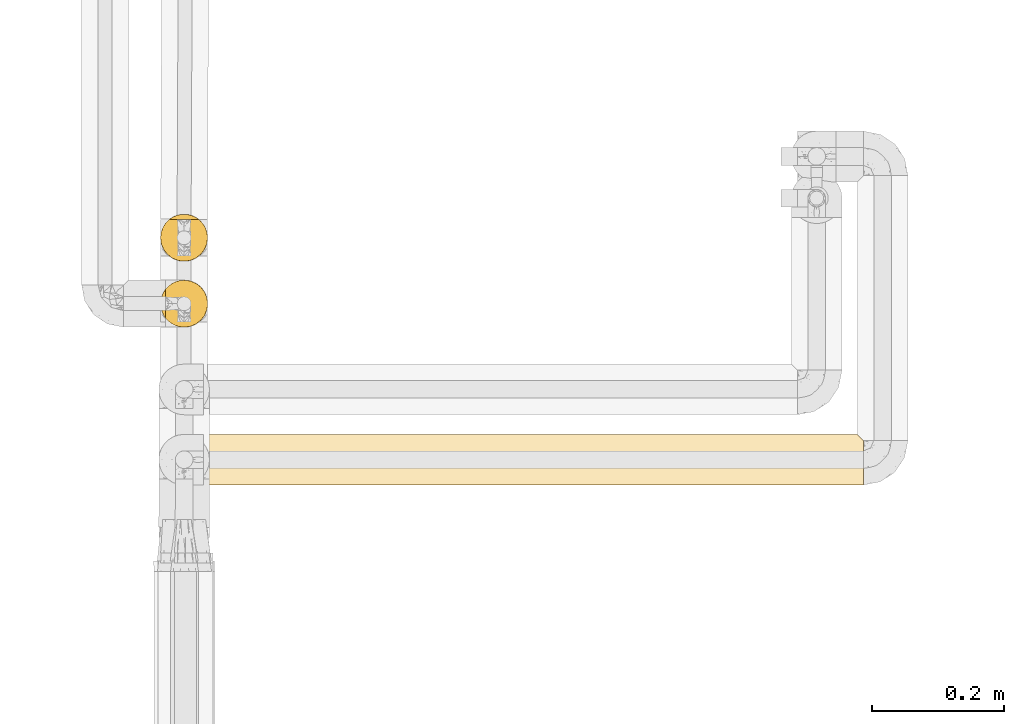
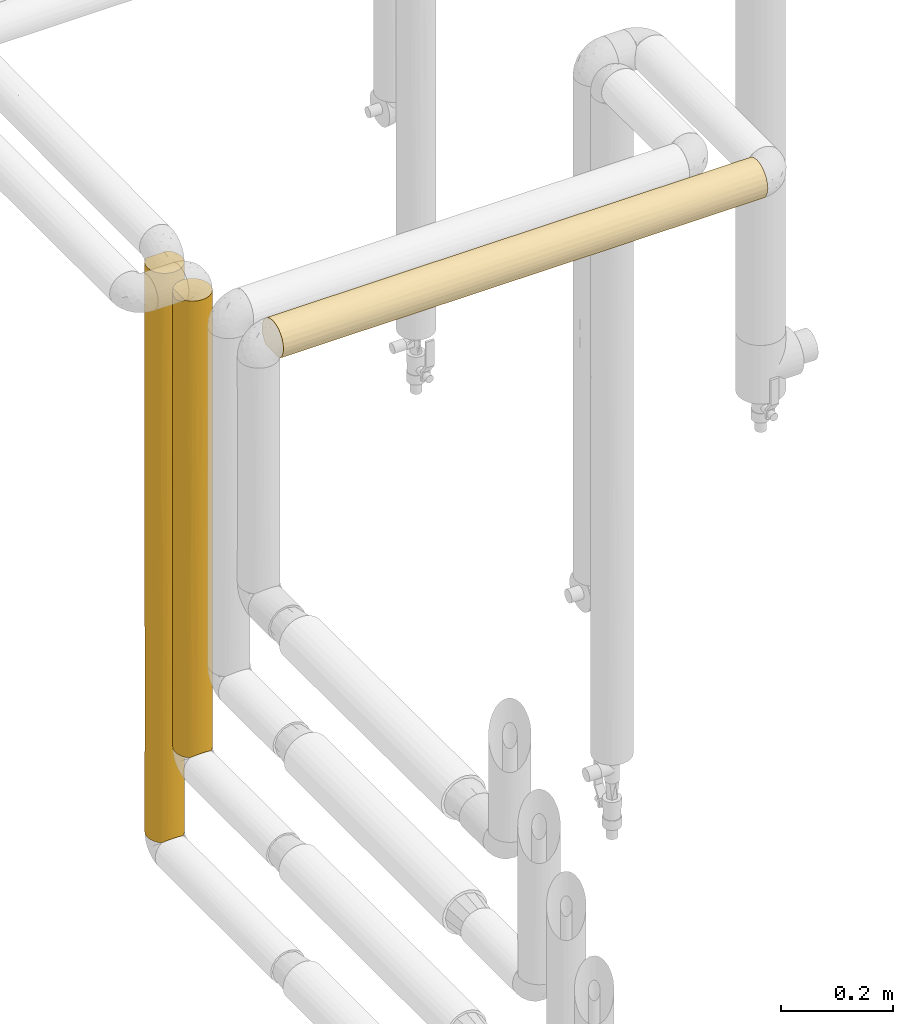
# One storey, part 29 of 827: 3 coverings.
"""IFC2X3 building model written with IfcOpenShell, lengths in millimetres."""

from ifc_helpers import new_model, entity, si_unit, converted_unit, derived_unit, direction, frame, origin, place, context, subcontext, project, spatial, faceted_brep, element, save


model = new_model("IFC2X3")

# Units and contexts
model_context = context("Model", 3, precision=0.01, world=origin(), true_north=direction((6.12303176911189e-17, 1.0)))
body_context = subcontext(model_context, "Body", "Model", "MODEL_VIEW")
ifc_project = project(units=[si_unit("LENGTHUNIT", "METRE", prefix="MILLI"), si_unit("AREAUNIT", "SQUARE_METRE"), si_unit("VOLUMEUNIT", "CUBIC_METRE"), converted_unit("PLANEANGLEUNIT", "DEGREE", entity("IfcRatioMeasure", 0.0174532925199433), si_unit("PLANEANGLEUNIT", "RADIAN"), dimensions=[0, 0, 0, 0, 0, 0, 0]), si_unit("MASSUNIT", "GRAM", prefix="KILO"), derived_unit("MASSDENSITYUNIT", [(si_unit("MASSUNIT", "GRAM", prefix="KILO"), 1), (si_unit("LENGTHUNIT", "METRE"), -3)]), derived_unit("MOMENTOFINERTIAUNIT", [(si_unit("LENGTHUNIT", "METRE"), 4)]), si_unit("TIMEUNIT", "SECOND"), si_unit("FREQUENCYUNIT", "HERTZ"), si_unit("THERMODYNAMICTEMPERATUREUNIT", "DEGREE_CELSIUS"), derived_unit("THERMALTRANSMITTANCEUNIT", [(si_unit("MASSUNIT", "GRAM", prefix="KILO"), 1), (si_unit("THERMODYNAMICTEMPERATUREUNIT", "KELVIN"), -1), (si_unit("TIMEUNIT", "SECOND"), -3)]), derived_unit("VOLUMETRICFLOWRATEUNIT", [(si_unit("LENGTHUNIT", "METRE"), 3), (si_unit("TIMEUNIT", "SECOND"), -1)]), derived_unit("MASSFLOWRATEUNIT", [(si_unit("MASSUNIT", "GRAM", prefix="KILO"), 1), (si_unit("TIMEUNIT", "SECOND"), -1)]), derived_unit("ROTATIONALFREQUENCYUNIT", [(si_unit("TIMEUNIT", "SECOND"), -1)]), si_unit("ELECTRICCURRENTUNIT", "AMPERE"), si_unit("ELECTRICVOLTAGEUNIT", "VOLT"), si_unit("POWERUNIT", "WATT"), si_unit("FORCEUNIT", "NEWTON", prefix="KILO"), si_unit("ILLUMINANCEUNIT", "LUX"), si_unit("LUMINOUSFLUXUNIT", "LUMEN"), si_unit("LUMINOUSINTENSITYUNIT", "CANDELA"), derived_unit("USERDEFINED", [(si_unit("MASSUNIT", "GRAM", prefix="KILO"), -1), (si_unit("LENGTHUNIT", "METRE"), -2), (si_unit("TIMEUNIT", "SECOND"), 3), (si_unit("LUMINOUSFLUXUNIT", "LUMEN"), 1)]), derived_unit("LINEARVELOCITYUNIT", [(si_unit("LENGTHUNIT", "METRE"), 1), (si_unit("TIMEUNIT", "SECOND"), -1)]), si_unit("PRESSUREUNIT", "PASCAL"), derived_unit("USERDEFINED", [(si_unit("LENGTHUNIT", "METRE"), -2), (si_unit("MASSUNIT", "GRAM", prefix="KILO"), 1), (si_unit("TIMEUNIT", "SECOND"), -2)]), derived_unit("LINEARFORCEUNIT", [(si_unit("MASSUNIT", "GRAM", prefix="KILO"), 1), (si_unit("LENGTHUNIT", "METRE"), 1), (si_unit("TIMEUNIT", "SECOND"), -2), (si_unit("LENGTHUNIT", "METRE"), -1)]), derived_unit("PLANARFORCEUNIT", [(si_unit("MASSUNIT", "GRAM", prefix="KILO"), 1), (si_unit("LENGTHUNIT", "METRE"), 1), (si_unit("TIMEUNIT", "SECOND"), -2), (si_unit("LENGTHUNIT", "METRE"), -2)])], contexts=[model_context])

# Site, building, storey
site_placement = place(None, origin())
site = spatial("IfcSite", under=ifc_project, at=site_placement, CompositionType="ELEMENT")
building_placement = place(site_placement, origin())
building = spatial("IfcBuilding", under=site, at=building_placement, CompositionType="ELEMENT")
storey_placement = place(building_placement, frame((0.0, 0.0, 28200.0)))
storey = spatial("IfcBuildingStorey", under=building, at=storey_placement, Name="08", CompositionType="ELEMENT", Elevation=28200.0)

# Coverings
covering_1_placement = place(storey_placement, frame((17954.23, 11719.52, 1860.0)))
element("IfcCovering", 1, at=covering_1_placement, inside=storey, Name=":ADSK_", ObjectType=":ADSK_", PredefinedType="INSULATION", context=body_context, shape_type="Brep", body=[
    faceted_brep([(1.6, 2.48, 31.79), (1.6, 1.6, 40.0), (1.6, 2.9, 49.93), (1.6, 6.74, 59.2), (1.6, 12.84, 67.15), (1.6, 20.8, 73.25), (1.6, 30.06, 77.09), (1.6, 40.0, 78.4), (1.6, 49.93, 77.09), (1.6, 59.2, 73.25), (1.6, 67.15, 67.15), (1.6, 73.25, 59.2), (1.6, 77.09, 49.93), (1.6, 78.4, 40.0), (1.6, 77.51, 31.79), (1.6, 74.9, 23.98), (1.6, 70.68, 16.91), (1.6, 65.05, 10.9), (1.6, 14.94, 10.9), (1.6, 9.31, 16.91), (1.6, 5.09, 23.98), (1002.81, 2.9, 30.06), (1002.81, 6.74, 20.8), (1002.81, 12.84, 12.84), (1002.81, 20.8, 6.74), (1002.81, 30.06, 2.9), (1002.81, 40.0, 1.6), (1002.81, 48.2, 2.48), (1002.81, 56.01, 5.09), (1002.81, 63.08, 9.31), (1002.81, 69.1, 14.94), (1002.81, 69.1, 65.05), (1002.81, 63.08, 70.68), (1002.81, 56.01, 74.9), (1002.81, 48.2, 77.51), (1002.81, 40.0, 78.4), (1002.81, 30.06, 77.09), (1002.81, 20.8, 73.25), (1002.81, 12.84, 67.15), (1002.81, 6.74, 59.2), (1002.81, 2.9, 49.93), (1002.81, 1.6, 40.0), (805.75, 74.63, 23.4), (998.84, 73.07, 20.48), (724.44, 71.09, 17.46), (10.29, 46.78, 2.2), (227.27, 40.0, 1.6), (10.9, 40.0, 1.6), (498.43, 62.65, 8.99), (241.24, 62.5, 8.88), (364.28, 69.52, 15.44), (373.51, 57.18, 5.66), (5.57, 59.51, 6.92), (748.28, 64.93, 10.79), (505.1, 74.56, 23.26), (718.51, 77.02, 29.8), (678.61, 59.07, 6.67), (994.12, 77.79, 33.21), (995.91, 76.0, 26.63), (209.78, 73.09, 20.52), (777.14, 78.4, 40.0), (560.77, 78.4, 40.0), (723.23, 40.0, 1.6), (667.89, 52.17, 3.58), (479.98, 77.35, 31.1), (259.3, 76.41, 27.82), (217.97, 78.4, 40.0), (317.48, 50.2, 2.98), (993.51, 78.4, 40.0), (443.64, 40.0, 1.6), (8.5, 53.36, 4.0), (281.18, 78.4, 40.0), (705.21, 25.3, 4.52), (572.52, 2.34, 32.45), (786.44, 1.6, 40.0), (718.58, 1.6, 40.0), (434.34, 1.6, 40.0), (583.43, 32.69, 2.3), (378.81, 22.81, 5.65), (505.39, 17.34, 8.99), (715.2, 4.52, 25.3), (435.92, 7.01, 20.33), (749.58, 9.53, 16.62), (774.52, 16.62, 9.53), (244.85, 17.48, 8.89), (319.2, 11.45, 14.31), (317.48, 29.79, 2.98), (8.5, 26.63, 4.0), (10.29, 33.21, 2.2), (5.57, 20.48, 6.92), (791.86, 2.41, 32.11), (217.97, 1.6, 40.0), (326.15, 2.98, 29.79), (538.92, 10.97, 14.85), (202.48, 7.01, 20.33), (801.82, 32.96, 2.25), (773.46, 9.53, 63.37), (689.64, 4.52, 54.69), (230.94, 9.53, 63.37), (290.41, 16.62, 70.46), (490.02, 14.57, 68.78), (433.47, 25.3, 75.47), (314.77, 4.52, 54.69), (502.2, 9.53, 63.37), (576.46, 2.26, 47.1), (326.15, 2.25, 47.03), (689.64, 16.62, 70.46), (442.37, 33.14, 77.78), (678.25, 32.78, 77.71), (570.07, 40.0, 78.4), (797.73, 2.26, 47.12), (240.71, 22.62, 74.24), (235.37, 29.41, 76.91), (745.73, 25.3, 75.47), (786.44, 40.0, 78.4), (217.97, 40.0, 78.4), (285.83, 40.0, 78.4), (801.92, 59.66, 72.98), (736.83, 52.17, 76.41), (625.6, 74.34, 57.18), (299.2, 75.47, 54.69), (499.01, 71.0, 62.65), (568.49, 59.66, 72.98), (281.3, 63.37, 70.46), (198.12, 54.69, 75.47), (201.98, 47.7, 77.61), (399.82, 50.18, 77.02), (685.2, 65.69, 68.54), (759.55, 71.11, 62.51), (994.12, 77.79, 46.78), (686.93, 77.01, 50.2), (229.89, 70.46, 63.37), (480.12, 64.93, 69.2), (995.91, 76.0, 53.36), (420.97, 77.69, 47.3), (998.84, 73.07, 59.51), (202.58, 77.75, 47.03)], [[[0, 1, 2, 3, 4, 5, 6, 7, 8, 9, 10, 11, 12, 13, 14, 15, 16, 17, 18, 19, 20]], [[21, 22, 23, 24, 25, 26, 27, 28, 29, 30, 31, 32, 33, 34, 35, 36, 37, 38, 39, 40, 41]], [[42, 43, 44]], [[45, 46, 47]], [[48, 49, 50]], [[51, 52, 49]], [[53, 30, 29]], [[54, 55, 42]], [[56, 48, 53]], [[55, 57, 58]], [[44, 50, 54]], [[50, 59, 54]], [[60, 55, 61]], [[27, 62, 63]], [[55, 54, 64]], [[58, 42, 55]], [[15, 65, 59]], [[64, 54, 65]], [[43, 30, 44]], [[50, 17, 16]], [[27, 63, 28]], [[14, 13, 66]], [[60, 57, 55]], [[67, 46, 45]], [[15, 14, 65]], [[52, 17, 49]], [[57, 60, 68]], [[69, 67, 63]], [[70, 67, 45]], [[28, 63, 56]], [[70, 52, 51]], [[43, 42, 58]], [[63, 67, 51]], [[44, 53, 48]], [[51, 49, 48]], [[50, 44, 48]], [[17, 50, 49]], [[59, 16, 15]], [[14, 66, 65]], [[64, 66, 71, 61]], [[51, 48, 56]], [[70, 51, 67]], [[66, 64, 65]], [[61, 55, 64]], [[54, 59, 65]], [[16, 59, 50]], [[67, 69, 46]], [[30, 53, 44]], [[29, 28, 56]], [[56, 53, 29]], [[51, 56, 63]], [[62, 27, 26]], [[62, 69, 63]], [[54, 42, 44]], [[24, 72, 25]], [[73, 74, 75, 76]], [[77, 69, 62]], [[78, 72, 79]], [[80, 81, 82]], [[83, 72, 24]], [[80, 82, 22]], [[18, 84, 85]], [[86, 87, 88]], [[87, 86, 78]], [[24, 23, 83]], [[84, 18, 89]], [[88, 46, 86]], [[41, 74, 90]], [[91, 92, 76]], [[92, 73, 76]], [[82, 81, 93]], [[20, 94, 92]], [[83, 82, 93]], [[21, 80, 22]], [[94, 20, 19]], [[78, 79, 84]], [[0, 91, 1]], [[80, 90, 73]], [[95, 72, 77]], [[89, 87, 78]], [[94, 85, 81]], [[20, 92, 0]], [[91, 0, 92]], [[23, 22, 82]], [[81, 80, 73]], [[77, 86, 69]], [[25, 95, 26]], [[81, 85, 93]], [[19, 18, 85]], [[92, 94, 81]], [[19, 85, 94]], [[79, 85, 84]], [[82, 83, 23]], [[72, 83, 79]], [[95, 77, 62]], [[77, 72, 78]], [[85, 79, 93]], [[83, 93, 79]], [[26, 95, 62]], [[72, 95, 25]], [[78, 84, 89]], [[78, 86, 77]], [[81, 73, 92]], [[80, 21, 90]], [[41, 90, 21]], [[74, 73, 90]], [[46, 88, 47]], [[46, 69, 86]], [[96, 97, 39]], [[98, 99, 4]], [[100, 101, 99]], [[98, 102, 97, 103]], [[39, 97, 40]], [[76, 104, 105]], [[38, 96, 39]], [[76, 105, 91]], [[98, 4, 3]], [[3, 2, 102]], [[37, 106, 38]], [[107, 101, 108]], [[108, 109, 107]], [[110, 97, 104]], [[101, 111, 99]], [[112, 111, 101]], [[5, 4, 99]], [[106, 37, 113]], [[109, 108, 114]], [[115, 7, 6]], [[36, 35, 114]], [[106, 100, 96]], [[2, 91, 105]], [[102, 105, 104]], [[113, 37, 36]], [[107, 112, 101]], [[100, 98, 103, 96]], [[114, 108, 36]], [[40, 110, 41]], [[101, 106, 113]], [[102, 98, 3]], [[106, 96, 38]], [[97, 96, 103]], [[2, 1, 91]], [[76, 75, 104]], [[2, 105, 102]], [[110, 104, 75]], [[102, 104, 97]], [[101, 113, 108]], [[36, 108, 113]], [[107, 109, 116, 115]], [[112, 115, 6]], [[115, 112, 107]], [[111, 6, 5]], [[6, 111, 112]], [[5, 99, 111]], [[110, 75, 74, 41]], [[97, 110, 40]], [[101, 100, 106]], [[98, 100, 99]], [[117, 118, 33]], [[119, 120, 121]], [[33, 32, 117]], [[122, 123, 124]], [[125, 126, 124]], [[127, 31, 128]], [[129, 60, 130]], [[34, 118, 114]], [[9, 8, 124]], [[131, 123, 132]], [[118, 126, 109]], [[125, 7, 115, 116]], [[127, 122, 117]], [[32, 31, 127]], [[133, 130, 119]], [[10, 9, 123]], [[34, 33, 118]], [[11, 10, 131]], [[130, 133, 129]], [[118, 109, 114]], [[119, 121, 128]], [[11, 131, 120]], [[123, 122, 132]], [[134, 61, 71]], [[120, 12, 11]], [[135, 133, 119]], [[126, 118, 122]], [[135, 128, 31]], [[114, 35, 34]], [[136, 120, 134]], [[123, 9, 124]], [[122, 127, 132]], [[134, 130, 61]], [[12, 136, 13]], [[118, 117, 122]], [[32, 127, 117]], [[121, 127, 128]], [[123, 131, 10]], [[120, 131, 121]], [[136, 134, 71]], [[134, 120, 119]], [[136, 71, 66, 13]], [[120, 136, 12]], [[119, 128, 135]], [[119, 130, 134]], [[125, 124, 8]], [[109, 126, 116]], [[124, 126, 122]], [[7, 125, 8]], [[116, 126, 125]], [[127, 121, 132]], [[131, 132, 121]], [[60, 129, 68]], [[60, 61, 130]], [[17, 52, 70, 45, 47, 88, 87, 89, 18]], [[68, 129, 133, 135, 31, 30, 43, 58, 57]]]),
])
covering_2_placement = place(storey_placement, frame((17889.48, 11958.96, 872.15)))
element("IfcCovering", 2, at=covering_2_placement, inside=storey, Name=":ADSK_", ObjectType=":ADSK_", PredefinedType="INSULATION", context=body_context, shape_type="Brep", body=[
    faceted_brep([(2.5, 29.26, 1.6), (1.6, 37.25, 1.6), (2.81, 46.47, 1.6), (6.37, 55.07, 1.6), (12.04, 62.45, 1.6), (19.42, 68.12, 1.6), (28.02, 71.68, 1.6), (37.25, 72.9, 1.6), (46.47, 71.68, 1.6), (55.07, 68.12, 1.6), (62.45, 62.45, 1.6), (68.12, 55.07, 1.6), (71.68, 46.47, 1.6), (72.9, 37.25, 1.6), (71.99, 29.26, 1.6), (69.32, 21.68, 1.6), (65.02, 14.89, 1.6), (59.31, 9.25, 1.6), (15.18, 9.25, 1.6), (9.47, 14.89, 1.6), (5.17, 21.68, 1.6), (46.47, 71.68, 999.85), (37.25, 72.9, 999.85), (29.26, 71.99, 999.85), (21.68, 69.32, 999.85), (14.89, 65.02, 999.85), (9.25, 59.31, 999.85), (9.25, 15.18, 999.85), (14.89, 9.47, 999.85), (21.68, 5.17, 999.85), (29.26, 2.5, 999.85), (37.25, 1.6, 999.85), (46.47, 2.81, 999.85), (55.07, 6.37, 999.85), (62.45, 12.04, 999.85), (68.12, 19.42, 999.85), (71.68, 28.02, 999.85), (72.9, 37.25, 999.85), (71.68, 46.47, 999.85), (68.12, 55.07, 999.85), (62.45, 62.45, 999.85), (55.07, 68.12, 999.85), (25.39, 3.62, 695.7), (37.25, 1.6, 713.03), (7.59, 17.46, 758.69), (13.2, 10.93, 705.91), (25.57, 3.56, 7.28), (31.32, 2.09, 8.75), (28.33, 2.73, 288.86), (7.13, 18.17, 292.32), (17.46, 7.59, 245.03), (20.14, 5.97, 4.87), (18.93, 6.66, 700.34), (37.25, 1.6, 217.73), (31.01, 2.14, 552.72), (24.15, 4.09, 474.28), (2.92, 27.6, 312.11), (1.6, 37.25, 783.72), (2.09, 31.32, 992.69), (1.6, 37.25, 992.2), (17.31, 7.69, 501.57), (11.91, 12.16, 332.36), (4.74, 22.61, 569.38), (9.1, 15.37, 520.98), (3.56, 25.57, 994.17), (5.97, 20.14, 996.57), (2.39, 29.78, 537.96), (2.72, 28.35, 753.82), (1.6, 37.25, 575.24), (1.6, 37.25, 210.08), (1.6, 37.25, 392.66), (1.6, 37.25, 288.42), (37.25, 1.6, 9.25), (37.25, 1.6, 426.21), (3.56, 48.92, 994.17), (7.59, 57.03, 757.03), (2.73, 46.16, 712.59), (2.09, 43.17, 992.69), (8.96, 58.95, 234.65), (15.54, 65.53, 242.48), (2.92, 46.89, 357.32), (4.95, 52.34, 208.04), (5.97, 54.35, 996.57), (7.69, 57.18, 501.07), (12.59, 63.0, 695.77), (18.17, 67.36, 807.9), (30.43, 72.24, 437.56), (37.25, 72.9, 582.89), (37.25, 72.9, 418.56), (37.25, 72.9, 292.24), (25.39, 70.87, 743.27), (18.17, 67.36, 583.64), (24.04, 70.36, 508.19), (30.22, 72.2, 221.96), (23.6, 70.18, 303.91), (12.77, 63.17, 466.4), (37.25, 72.9, 791.37), (37.25, 72.9, 210.08), (37.25, 72.9, 709.2), (58.95, 65.53, 768.4), (50.89, 70.18, 695.94), (58.95, 65.53, 233.04), (65.53, 58.95, 274.49), (64.39, 60.36, 485.21), (70.18, 50.89, 416.68), (50.89, 70.18, 305.51), (58.95, 65.53, 500.72), (44.16, 72.22, 558.81), (50.38, 70.39, 500.72), (43.74, 72.3, 314.32), (65.53, 58.95, 695.94), (71.85, 45.8, 237.41), (72.26, 43.96, 687.13), (72.9, 37.25, 582.89), (72.3, 43.73, 466.03), (44.28, 72.19, 772.34), (69.31, 52.83, 207.5), (72.9, 37.25, 791.37), (72.9, 37.25, 709.2), (70.18, 50.89, 758.63), (72.9, 37.25, 418.55), (72.9, 37.25, 292.24), (72.9, 37.25, 210.07), (70.18, 23.6, 697.53), (46.16, 2.73, 288.86), (57.18, 7.69, 500.38), (46.89, 2.92, 644.13), (57.03, 7.59, 244.42), (63.0, 12.59, 305.67), (70.87, 25.39, 258.18), (63.17, 12.77, 535.04), (65.53, 15.54, 758.96), (72.24, 30.43, 563.88), (67.36, 18.17, 417.81), (67.36, 18.17, 193.54), (58.95, 8.96, 766.79), (52.34, 4.95, 793.4), (70.36, 24.04, 493.26), (43.17, 2.09, 8.75), (48.92, 3.56, 7.28), (54.35, 5.97, 4.87), (72.2, 30.22, 779.48)], [[[0, 1, 2, 3, 4, 5, 6, 7, 8, 9, 10, 11, 12, 13, 14, 15, 16, 17, 18, 19, 20]], [[21, 22, 23, 24, 25, 26, 27, 28, 29, 30, 31, 32, 33, 34, 35, 36, 37, 38, 39, 40, 41]], [[42, 43, 30]], [[27, 44, 45]], [[46, 47, 48]], [[20, 19, 49]], [[50, 51, 46]], [[52, 29, 28]], [[47, 53, 48]], [[28, 45, 52]], [[54, 42, 55]], [[48, 50, 46]], [[18, 51, 50]], [[20, 56, 0]], [[57, 58, 59]], [[50, 55, 60]], [[50, 61, 18]], [[62, 63, 44]], [[64, 44, 65]], [[66, 67, 68]], [[62, 44, 67]], [[29, 42, 30]], [[55, 50, 48]], [[58, 67, 64]], [[63, 62, 49]], [[44, 27, 65]], [[67, 44, 64]], [[61, 63, 49]], [[48, 54, 55]], [[42, 52, 55]], [[49, 62, 56]], [[44, 63, 45]], [[61, 19, 18]], [[69, 1, 0]], [[61, 60, 63]], [[58, 57, 67]], [[20, 49, 56]], [[70, 56, 66]], [[45, 63, 60]], [[52, 45, 60]], [[27, 45, 28]], [[66, 62, 67]], [[0, 56, 69]], [[19, 61, 49]], [[60, 61, 50]], [[56, 70, 71, 69]], [[56, 62, 66]], [[66, 68, 70]], [[55, 52, 60]], [[29, 52, 42]], [[53, 47, 72]], [[53, 73, 48]], [[57, 68, 67]], [[30, 43, 31]], [[54, 48, 73]], [[54, 43, 42]], [[43, 54, 73]], [[74, 75, 76]], [[77, 74, 76]], [[4, 78, 79]], [[2, 80, 81]], [[59, 77, 57]], [[75, 82, 26]], [[77, 76, 57]], [[83, 78, 81]], [[84, 83, 75]], [[84, 25, 85]], [[2, 71, 80]], [[86, 87, 88, 89]], [[80, 68, 76]], [[76, 83, 80]], [[24, 23, 90]], [[85, 90, 91]], [[92, 90, 86]], [[93, 94, 86]], [[79, 5, 4]], [[75, 74, 82]], [[86, 90, 87]], [[26, 25, 84]], [[95, 83, 84]], [[94, 6, 5]], [[76, 68, 57]], [[76, 75, 83]], [[85, 25, 24]], [[23, 96, 90]], [[94, 5, 79]], [[4, 3, 78]], [[91, 94, 79]], [[81, 78, 3]], [[6, 93, 7]], [[95, 78, 83]], [[90, 85, 24]], [[84, 85, 91]], [[84, 91, 95]], [[84, 75, 26]], [[91, 79, 95]], [[78, 95, 79]], [[93, 86, 89]], [[86, 94, 92]], [[93, 89, 97, 7]], [[6, 94, 93]], [[2, 81, 3]], [[83, 81, 80]], [[94, 91, 92]], [[90, 92, 91]], [[2, 1, 69, 71]], [[80, 71, 70, 68]], [[96, 23, 22]], [[90, 96, 98, 87]], [[99, 100, 41]], [[101, 102, 10]], [[103, 104, 102]], [[101, 105, 106]], [[100, 99, 106]], [[41, 100, 21]], [[107, 100, 108]], [[40, 99, 41]], [[109, 97, 89, 88]], [[101, 10, 9]], [[9, 8, 105]], [[39, 110, 40]], [[12, 111, 13]], [[112, 113, 114]], [[105, 108, 106]], [[107, 115, 100]], [[104, 116, 102]], [[111, 116, 104]], [[102, 11, 10]], [[106, 99, 110]], [[112, 117, 118, 113]], [[114, 111, 104]], [[119, 110, 39]], [[8, 97, 109]], [[109, 107, 108]], [[119, 39, 38]], [[112, 114, 104]], [[110, 103, 106]], [[117, 112, 38]], [[21, 115, 22]], [[104, 110, 119]], [[105, 101, 9]], [[101, 106, 103]], [[110, 99, 40]], [[8, 7, 97]], [[109, 88, 107]], [[8, 109, 105]], [[107, 88, 87, 98]], [[115, 107, 98]], [[38, 37, 117]], [[104, 119, 112]], [[38, 112, 119]], [[114, 113, 120, 121]], [[111, 121, 122, 13]], [[121, 111, 114]], [[116, 12, 11]], [[12, 116, 111]], [[11, 102, 116]], [[115, 98, 96, 22]], [[21, 100, 115]], [[106, 108, 100]], [[109, 108, 105]], [[104, 103, 110]], [[101, 103, 102]], [[123, 36, 35]], [[124, 125, 126]], [[127, 128, 125]], [[14, 122, 129]], [[128, 130, 125]], [[35, 34, 131]], [[132, 120, 113, 118]], [[123, 35, 131]], [[133, 134, 129]], [[15, 14, 129]], [[132, 129, 120]], [[134, 16, 15]], [[125, 135, 136]], [[128, 16, 134]], [[137, 129, 132]], [[17, 16, 128]], [[53, 138, 124]], [[124, 127, 125]], [[138, 139, 124]], [[32, 43, 126]], [[140, 17, 127]], [[127, 124, 139]], [[72, 138, 53]], [[124, 126, 73]], [[32, 126, 136]], [[124, 73, 53]], [[34, 135, 131]], [[141, 123, 132]], [[127, 139, 140]], [[34, 33, 135]], [[133, 123, 131]], [[136, 135, 33]], [[36, 141, 37]], [[130, 135, 125]], [[129, 134, 15]], [[128, 134, 133]], [[128, 133, 130]], [[128, 127, 17]], [[133, 131, 130]], [[135, 130, 131]], [[141, 132, 118]], [[132, 123, 137]], [[141, 118, 117, 37]], [[36, 123, 141]], [[32, 136, 33]], [[125, 136, 126]], [[123, 133, 137]], [[129, 137, 133]], [[43, 32, 31]], [[43, 73, 126]], [[122, 14, 13]], [[129, 122, 121, 120]], [[139, 138, 72, 47, 46, 51, 18, 17, 140]], [[59, 58, 64, 65, 27, 26, 82, 74, 77]]]),
])
covering_3_placement = place(storey_placement, frame((17889.35, 12058.96, 625.85)))
element("IfcCovering", 3, at=covering_3_placement, inside=storey, Name=":ADSK_", ObjectType=":ADSK_", PredefinedType="INSULATION", context=body_context, shape_type="Brep", body=[
    faceted_brep([(62.45, 12.04, 1246.15), (68.12, 19.42, 1246.15), (71.68, 28.02, 1246.15), (72.9, 37.25, 1246.15), (71.99, 45.24, 1246.15), (69.32, 52.81, 1246.15), (65.02, 59.6, 1246.15), (59.31, 65.25, 1246.15), (15.18, 65.25, 1246.15), (9.47, 59.6, 1246.15), (5.17, 52.81, 1246.15), (2.5, 45.24, 1246.15), (1.6, 37.25, 1246.15), (2.81, 28.02, 1246.15), (6.37, 19.42, 1246.15), (12.04, 12.04, 1246.15), (19.42, 6.37, 1246.15), (28.02, 2.81, 1246.15), (37.25, 1.6, 1246.15), (46.47, 2.81, 1246.15), (55.07, 6.37, 1246.15), (71.68, 46.47, 1.6), (72.9, 37.25, 1.6), (71.98, 29.24, 1.6), (69.3, 21.65, 1.6), (64.99, 14.86, 1.6), (59.26, 9.21, 1.6), (15.36, 9.1, 1.6), (9.58, 14.76, 1.6), (5.22, 21.58, 1.6), (2.52, 29.2, 1.6), (1.6, 37.25, 1.6), (2.81, 46.47, 1.6), (6.37, 55.07, 1.6), (12.04, 62.45, 1.6), (19.42, 68.12, 1.6), (28.02, 71.68, 1.6), (37.25, 72.9, 1.6), (46.47, 71.68, 1.6), (55.07, 68.12, 1.6), (62.45, 62.45, 1.6), (68.12, 55.07, 1.6), (3.65, 25.31, 269.77), (2.95, 27.51, 600.94), (1.6, 37.25, 418.56), (12.31, 11.77, 269.76), (16.77, 8.06, 411.08), (10.87, 13.26, 624.73), (25.68, 3.52, 7.2), (22.79, 4.66, 334.3), (17.75, 7.4, 200.1), (1.6, 37.25, 210.08), (7.21, 18.04, 208.33), (31.38, 2.08, 8.66), (30.28, 2.28, 321.88), (37.25, 1.6, 217.64), (8.96, 15.54, 859.05), (8.96, 15.54, 1075.96), (4.31, 23.6, 982.52), (2.21, 30.63, 936.59), (3.45, 25.88, 795.05), (23.6, 4.31, 916.45), (15.54, 8.96, 999.03), (13.99, 10.22, 795.24), (7.21, 18.04, 445.78), (23.94, 4.17, 523.49), (29.15, 2.53, 634.6), (22.97, 4.58, 713.69), (20.29, 5.89, 4.82), (30.67, 2.21, 940.37), (37.25, 1.6, 426.12), (17.42, 7.62, 623.59), (37.25, 1.6, 1037.67), (37.25, 1.6, 9.15), (1.6, 37.25, 1037.67), (6.26, 19.61, 674.57), (1.6, 37.25, 835.52), (1.6, 37.25, 829.19), (1.6, 37.25, 627.04), (1.6, 37.25, 620.7), (37.25, 1.6, 634.6), (37.25, 1.6, 843.08), (1.6, 37.25, 412.23), (67.34, 18.13, 208.14), (62.29, 11.87, 269.03), (57.2, 7.7, 623.79), (63.72, 13.37, 625.44), (60.6, 10.31, 795.88), (50.89, 4.31, 915.17), (43.15, 2.09, 8.68), (48.89, 3.55, 7.23), (44.26, 2.29, 321.88), (56.8, 7.43, 200.15), (70.86, 25.37, 269.03), (72.9, 37.25, 210.08), (72.9, 37.25, 412.23), (72.9, 37.25, 418.56), (67.34, 18.13, 445.14), (43.83, 2.21, 940.37), (72.28, 30.63, 936.59), (70.18, 23.6, 983.26), (65.53, 15.54, 1077.26), (51.8, 4.7, 334.67), (58.95, 8.96, 998.7), (65.53, 15.54, 861.37), (71.55, 27.55, 597.3), (71.02, 25.85, 793.05), (68.29, 19.72, 668.93), (47.57, 3.12, 614.38), (57.91, 8.19, 408.95), (54.31, 5.95, 4.84), (72.9, 37.25, 620.71), (72.9, 37.25, 627.04), (72.9, 37.25, 829.19), (72.9, 37.25, 835.52), (72.9, 37.25, 1037.67), (70.87, 49.1, 979.01), (44.29, 72.19, 925.78), (48.92, 70.93, 1240.47), (51.84, 69.77, 912.9), (58.95, 65.53, 249.17), (50.89, 70.18, 333.1), (37.25, 72.9, 210.08), (43.83, 72.28, 307.33), (47.59, 71.36, 632.43), (37.25, 72.9, 404.57), (37.25, 72.9, 613.06), (37.25, 72.9, 821.54), (67.36, 56.32, 1039.7), (62.32, 62.58, 979.01), (65.53, 58.95, 169.96), (72.28, 43.86, 311.15), (70.18, 50.89, 264.19), (67.36, 56.32, 802.9), (57.24, 66.76, 623.87), (57.95, 66.27, 838.92), (54.35, 68.52, 1242.87), (56.82, 67.04, 1047.52), (37.25, 72.9, 1030.02), (65.53, 58.95, 385.45), (60.76, 64.04, 449.24), (63.76, 61.08, 622.0), (71.55, 46.93, 651.84), (43.17, 72.4, 1239.0), (37.25, 72.9, 1238.5), (71.02, 48.66, 455.46), (68.31, 54.74, 580.08), (15.54, 65.53, 249.17), (17.61, 67.0, 1047.03), (20.14, 68.52, 1242.87), (23.6, 70.18, 333.1), (31.32, 72.4, 1239.0), (25.57, 70.93, 1240.47), (2.21, 43.86, 311.15), (30.66, 72.28, 307.33), (4.31, 50.89, 264.19), (3.47, 48.66, 455.46), (30.2, 72.19, 925.78), (22.89, 69.88, 537.12), (24.02, 70.35, 725.77), (29.16, 71.97, 613.06), (12.17, 62.58, 979.01), (16.41, 66.18, 836.51), (10.73, 61.08, 622.0), (22.66, 69.77, 912.9), (8.96, 58.95, 169.96), (8.96, 58.95, 385.45), (17.25, 66.76, 623.87), (13.85, 64.15, 451.6), (3.62, 49.1, 979.01), (7.13, 56.32, 1039.7), (7.13, 56.32, 802.9), (2.94, 46.93, 651.84), (6.18, 54.74, 580.08)], [[[0, 1, 2, 3, 4, 5, 6, 7, 8, 9, 10, 11, 12, 13, 14, 15, 16, 17, 18, 19, 20]], [[21, 22, 23, 24, 25, 26, 27, 28, 29, 30, 31, 32, 33, 34, 35, 36, 37, 38, 39, 40, 41]], [[42, 43, 44]], [[45, 46, 47]], [[48, 49, 50]], [[42, 51, 30]], [[29, 52, 42]], [[48, 53, 54]], [[29, 28, 52]], [[55, 54, 53]], [[29, 42, 30]], [[56, 57, 58]], [[59, 60, 58]], [[61, 62, 63]], [[64, 52, 45]], [[65, 66, 67]], [[68, 48, 50]], [[16, 62, 61]], [[69, 17, 61]], [[54, 55, 70]], [[27, 45, 28]], [[54, 70, 66]], [[71, 63, 47]], [[57, 15, 14]], [[17, 72, 18]], [[16, 61, 17]], [[62, 16, 15]], [[54, 66, 65]], [[53, 73, 55]], [[13, 12, 74]], [[50, 27, 68]], [[14, 13, 58]], [[50, 49, 46]], [[43, 42, 64]], [[45, 52, 28]], [[47, 56, 75]], [[43, 76, 77, 78, 79, 44]], [[74, 76, 59]], [[58, 60, 75]], [[66, 70, 80, 81]], [[54, 49, 48]], [[69, 66, 81]], [[66, 69, 67]], [[57, 62, 15]], [[56, 47, 63]], [[42, 44, 82, 51]], [[51, 31, 30]], [[42, 52, 64]], [[60, 59, 76]], [[74, 59, 13]], [[13, 59, 58]], [[63, 67, 61]], [[43, 64, 75]], [[17, 69, 72]], [[81, 72, 69]], [[69, 61, 67]], [[58, 57, 14]], [[62, 57, 56]], [[56, 58, 75]], [[45, 47, 64]], [[43, 75, 60]], [[64, 47, 75]], [[63, 71, 67]], [[56, 63, 62]], [[49, 65, 46]], [[27, 50, 45]], [[47, 46, 71]], [[45, 50, 46]], [[76, 43, 60]], [[71, 46, 65]], [[71, 65, 67]], [[54, 65, 49]], [[83, 84, 25]], [[85, 86, 87]], [[26, 25, 84]], [[20, 19, 88]], [[83, 25, 24]], [[89, 90, 91]], [[92, 26, 84]], [[70, 55, 91]], [[93, 94, 95, 96]], [[84, 97, 86]], [[81, 98, 72]], [[99, 2, 100]], [[101, 100, 1]], [[91, 90, 102]], [[103, 20, 88]], [[19, 72, 98]], [[100, 2, 1]], [[104, 103, 87]], [[105, 106, 107]], [[0, 101, 1]], [[85, 88, 108]], [[103, 0, 20]], [[93, 24, 23]], [[85, 102, 109]], [[83, 93, 97]], [[55, 73, 89]], [[97, 93, 105]], [[110, 92, 90]], [[108, 81, 80, 70]], [[102, 108, 91]], [[109, 102, 92]], [[93, 23, 94]], [[105, 93, 96]], [[105, 96, 111, 112, 113, 114]], [[2, 115, 3]], [[86, 107, 104]], [[81, 108, 98]], [[89, 91, 55]], [[102, 85, 108]], [[98, 108, 88]], [[108, 70, 91]], [[87, 88, 85]], [[101, 103, 104]], [[23, 22, 94]], [[93, 83, 24]], [[84, 83, 97]], [[2, 99, 115]], [[114, 115, 99]], [[106, 99, 100]], [[104, 106, 100]], [[106, 105, 114]], [[19, 18, 72]], [[19, 98, 88]], [[103, 101, 0]], [[100, 101, 104]], [[86, 85, 109]], [[107, 86, 97]], [[105, 107, 97]], [[104, 107, 106]], [[104, 87, 86]], [[88, 87, 103]], [[102, 90, 92]], [[86, 109, 84]], [[26, 92, 110]], [[84, 109, 92]], [[114, 99, 106]], [[116, 115, 114, 113]], [[117, 118, 119]], [[120, 39, 121]], [[38, 122, 123]], [[124, 125, 126, 127]], [[6, 128, 129]], [[130, 41, 40]], [[131, 21, 132]], [[119, 124, 117]], [[41, 132, 21]], [[116, 133, 128]], [[134, 119, 135]], [[136, 137, 118]], [[127, 138, 117]], [[125, 123, 122]], [[139, 120, 140]], [[116, 5, 4]], [[129, 133, 141]], [[133, 116, 142]], [[137, 7, 129]], [[39, 38, 121]], [[130, 132, 41]], [[6, 5, 128]], [[143, 118, 117]], [[7, 6, 129]], [[40, 39, 120]], [[138, 144, 143]], [[139, 140, 141]], [[142, 145, 146]], [[121, 124, 134]], [[135, 119, 137]], [[116, 4, 115]], [[142, 116, 113]], [[142, 113, 112, 111, 96, 95]], [[21, 94, 22]], [[141, 146, 139]], [[125, 124, 123]], [[143, 117, 138]], [[119, 134, 124]], [[123, 124, 121]], [[124, 127, 117]], [[140, 121, 134]], [[130, 120, 139]], [[4, 3, 115]], [[116, 128, 5]], [[129, 128, 133]], [[21, 131, 94]], [[95, 94, 131]], [[145, 131, 132]], [[139, 145, 132]], [[145, 142, 95]], [[38, 37, 122]], [[38, 123, 121]], [[120, 130, 40]], [[132, 130, 139]], [[141, 134, 135]], [[146, 141, 133]], [[142, 146, 133]], [[139, 146, 145]], [[121, 140, 120]], [[134, 141, 140]], [[119, 118, 137]], [[141, 135, 129]], [[7, 137, 136]], [[129, 135, 137]], [[95, 131, 145]], [[34, 147, 35]], [[148, 8, 149]], [[36, 35, 150]], [[36, 122, 37]], [[151, 144, 138]], [[152, 148, 149]], [[153, 51, 82]], [[154, 36, 150]], [[155, 153, 156]], [[157, 138, 127]], [[158, 159, 160]], [[161, 162, 163]], [[152, 164, 148]], [[165, 155, 166]], [[33, 165, 34]], [[167, 168, 163]], [[152, 151, 157]], [[10, 169, 11]], [[33, 32, 155]], [[138, 157, 151]], [[8, 161, 9]], [[150, 35, 147]], [[127, 160, 157]], [[169, 74, 11]], [[9, 170, 10]], [[10, 170, 169]], [[150, 147, 168]], [[161, 171, 170]], [[159, 157, 160]], [[169, 172, 77]], [[161, 148, 162]], [[172, 169, 171]], [[11, 74, 12]], [[171, 163, 173]], [[172, 82, 44, 79, 78, 77]], [[51, 153, 32]], [[166, 155, 156]], [[160, 127, 126, 125]], [[157, 164, 152]], [[154, 160, 125]], [[160, 154, 158]], [[165, 147, 34]], [[166, 163, 168]], [[161, 170, 9]], [[169, 77, 76, 74]], [[169, 170, 171]], [[32, 31, 51]], [[156, 153, 82]], [[32, 153, 155]], [[168, 158, 150]], [[172, 171, 173]], [[36, 154, 122]], [[125, 122, 154]], [[154, 150, 158]], [[155, 165, 33]], [[147, 165, 166]], [[173, 166, 156]], [[161, 163, 171]], [[166, 173, 163]], [[172, 173, 156]], [[168, 167, 158]], [[166, 168, 147]], [[164, 159, 162]], [[8, 148, 161]], [[164, 162, 148]], [[163, 162, 167]], [[82, 172, 156]], [[167, 162, 159]], [[167, 159, 158]], [[157, 159, 164]], [[136, 118, 143, 144, 151, 152, 149, 8, 7]], [[110, 90, 89, 73, 53, 48, 68, 27, 26]]]),
])

save(model, "model.ifc")
